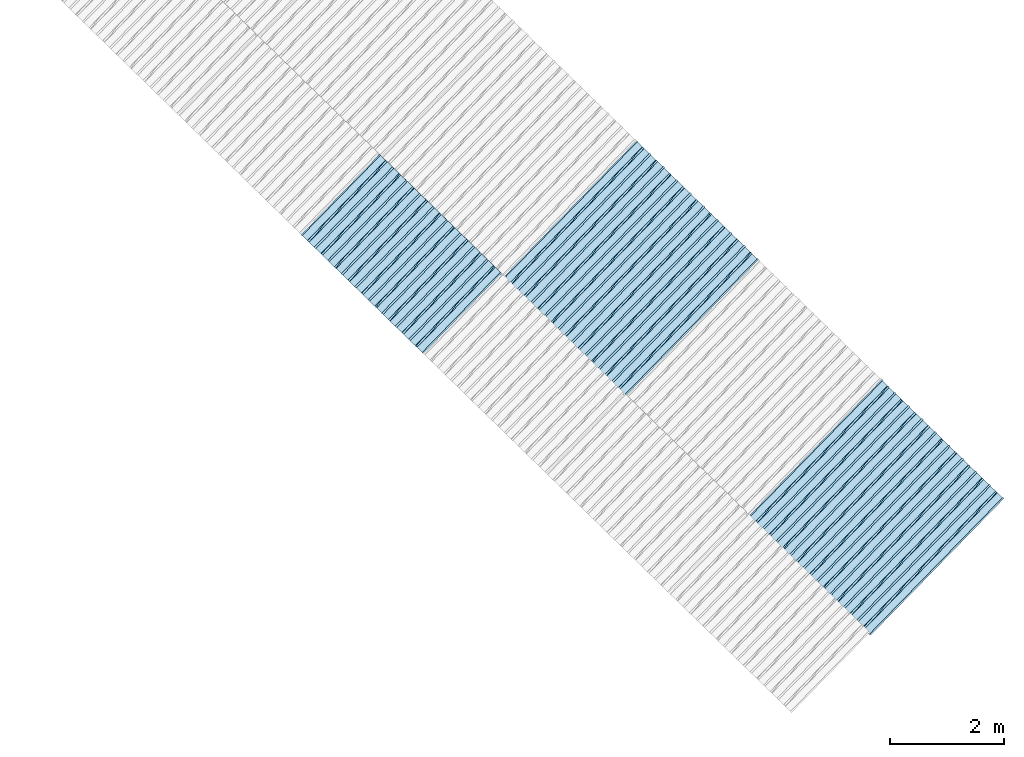
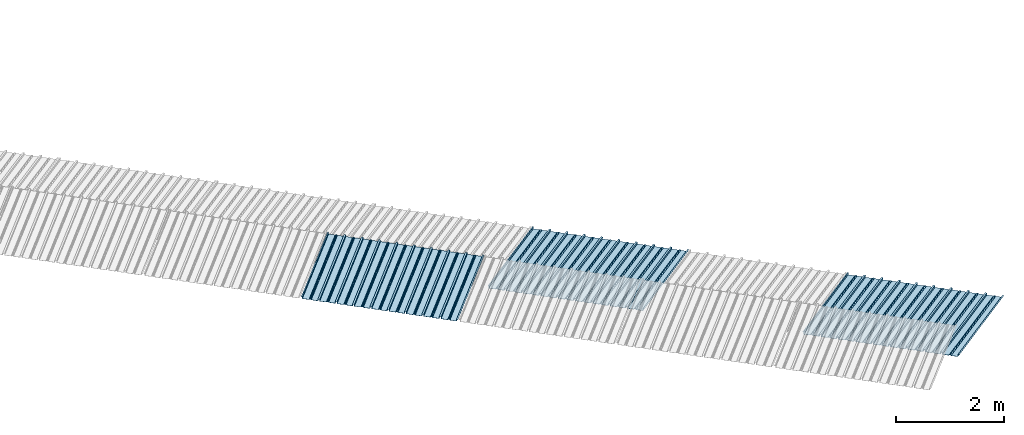
# One storey, part 4 of 8: 3 plates, 2 elements without a shape of their own.
"""IFC4 building model written with IfcOpenShell, lengths in metres."""

from ifc_helpers import new_model, entity, si_unit, converted_unit, direction, frame, origin, place, context, subcontext, project, spatial, line, arc, indexed_curve, outline, extrude, source, transform, mapped, material, type_object, type_shapes, element, aggregate, save


model = new_model("IFC4")

# Units and contexts
model_context = context("Model", 3, precision=1e-05, world=origin(), true_north=direction((6.123233995736766e-17, 1.0)))
body_context = subcontext(model_context, "Body", "Model", "MODEL_VIEW")
ifc_project = project(units=[si_unit("LENGTHUNIT", "METRE"), si_unit("AREAUNIT", "SQUARE_METRE"), si_unit("VOLUMEUNIT", "CUBIC_METRE"), converted_unit("PLANEANGLEUNIT", "DEGREE", entity("IfcPlaneAngleMeasure", 0.017453292519943278), si_unit("PLANEANGLEUNIT", "RADIAN"), dimensions=[0, 0, 0, 0, 0, 0, 0])], contexts=[model_context])

# Site, building, storey
site_placement = place(None, frame((0.0, 0.0, 0.0), z_axis=(0.0, 0.0, 1.0), x_axis=(0.7160934825303189, -0.6980043870045516, 0.0)))
site = spatial("IfcSite", under=ifc_project, at=site_placement, CompositionType="ELEMENT")
building_placement = place(site_placement, origin())
building = spatial("IfcBuilding", under=site, at=building_placement, CompositionType="ELEMENT")
storey_placement = place(building_placement, frame((0.0, 0.0, -1.24)))
storey = spatial("IfcBuildingStorey", under=building, at=storey_placement, Name="Livello 5", CompositionType="ELEMENT", Elevation=-1.24)

# Roof, plate
curtain_wall_type = type_object("IfcCurtainWallType", Name="Vetrata Copertura 2", PredefinedType="NOTDEFINED")
roof_1_placement = place(storey_placement, frame((0.0, 0.0, 1.24)))
roof_1 = element("IfcRoof", 1, at=roof_1_placement, inside=storey, type_object=curtain_wall_type, Name="Vetrata Copertura 2", ObjectType="Vetrata Copertura 2", PredefinedType="SHED_ROOF")
ifc_material = material(Name="Default")
plate_type_1 = type_object("IfcPlateType", Name="Pannello copertura:Pannello copertura", PredefinedType="CURTAIN_PANEL", material=ifc_material)
shared_shape_1 = source(origin(), body_context, "Body", "SweptSolid", [
    extrude(outline(indexed_curve([(1.339910560042256, -0.015785714285718594), (1.4699105600422562, -0.015785714285719003), (1.4699105600422562, 0.024214285714281004), (1.494919197675959, 0.02421428571428092), (1.494919197675959, 0.027214285714280917), (1.466910560042256, 0.027214285714281014), (1.466910560042256, -0.012785714285718995), (1.3417510978483753, -0.012785714285718492), (1.3199105600422556, 4.9134324369942785e-05), (1.2980700222361363, -0.012785714285718328), (1.1729105600422558, -0.01278571428571804), (1.1729105600422558, 0.02721428571428197), (1.136910560042256, 0.027214285714282097), (1.136910560042256, -0.012785714285717937), (1.0117510978483748, -0.01278571428571754), (0.9899105600422554, 4.913432437100935e-05), (0.968070022236136, -0.01278571428571726), (0.8429105600422558, -0.012785714285716971), (0.842910560042256, 0.027214285714283023), (0.8069105600422554, 0.027214285714283144), (0.8069105600422554, -0.01278571428571687), (0.6817510978483748, -0.012785714285716475), (0.6599105600422555, 4.9134324372075926e-05), (0.6380700222361361, -0.012785714285716196), (0.5129105600422553, -0.012785714285715915), (0.5129105600422554, 0.027214285714284105), (0.47691056004225557, 0.027214285714284227), (0.47691056004225557, -0.012785714285715804), (0.3517510978483749, -0.012785714285715427), (0.32991056004225544, 4.9134324373142496e-05), (0.3080700222361361, -0.012785714285715127), (0.18291056004225528, -0.012785714285714848), (0.18291056004225553, 0.027214285714285157), (0.1469105600422553, 0.02721428571428528), (0.14691056004225533, -0.012785714285714738), (0.021751097848374697, -0.01278571428571434), (-8.943995774469983e-05, 4.913432437420907e-05), (-0.021929977763864118, -0.01278571428571406), (-0.1470894399577447, -0.012785714285713783), (-0.14708943995774473, 0.02721428571428624), (-0.18308943995774493, 0.027214285714286364), (-0.1830894399577449, -0.012785714285713672), (-0.30824890215162537, -0.012785714285713215), (-0.33008943995774487, 4.9134324375275644e-05), (-0.3519299777638641, -0.012785714285712995), (-0.47708943995774494, -0.012785714285712714), (-0.4770894399577447, 0.02721428571428729), (-0.5130894399577449, 0.02721428571428741), (-0.5130894399577449, -0.012785714285712603), (-0.6382489021516256, -0.012785714285712207), (-0.6600894399577448, 4.9134324376342214e-05), (-0.6819299777638644, -0.012785714285711926), (-0.8070894399577453, -0.012785714285711647), (-0.807089439957745, 0.027214285714288373), (-0.843089439957745, 0.027214285714288494), (-0.8430894399577447, -0.012785714285711538), (-0.968248902151626, -0.012785714285711083), (-0.9900894399577453, 4.9134324377408785e-05), (-1.0119299777638646, -0.012785714285710861), (-1.1370894399577456, -0.012785714285710582), (-1.1370894399577451, 0.02721428571428942), (-1.1730894399577452, 0.027214285714289545), (-1.1730894399577454, -0.012785714285710473), (-1.2982489021516257, -0.012785714285710093), (-1.3200894399577452, 4.9134324378475355e-05), (-1.3419299777638647, -0.012785714285709794), (-1.4670894399577457, -0.012785714285709513), (-1.4670894399577454, 0.027214285714290503), (-1.490089439957745, 0.027214285714290586), (-1.490089439957745, 0.024214285714290556), (-1.4700894399577447, 0.02421428571429049), (-1.4700894399577449, -0.015785714285709514), (-1.3400894399577452, -0.015785714285709924), (-1.3200894399577452, -0.0029508656756215236), (-1.3000894399577452, -0.015785714285710063), (-1.170089439957745, -0.015785714285710472), (-1.1700894399577453, 0.024214285714289543), (-1.140089439957745, 0.02421428571428944), (-1.1400894399577455, -0.015785714285710583), (-1.0100894399577454, -0.015785714285710992), (-0.9900894399577453, -0.00295086567562259), (-0.9700894399577453, -0.015785714285711128), (-0.8400894399577448, -0.01578571428571154), (-0.8400894399577451, 0.024214285714288453), (-0.8100894399577452, 0.024214285714288356), (-0.8100894399577452, -0.015785714285711648), (-0.6800894399577451, -0.015785714285712012), (-0.6600894399577448, -0.0029508656756236573), (-0.6400894399577448, -0.015785714285712196), (-0.5100894399577451, -0.015785714285712606), (-0.5100894399577451, 0.024214285714287406), (-0.4800894399577449, 0.024214285714287305), (-0.4800894399577449, -0.015785714285712713), (-0.350089439957745, -0.01578571428571316), (-0.33008943995774487, -0.0029508656756247237), (-0.31008943995774485, -0.01578571428571326), (-0.1800894399577448, -0.015785714285713674), (-0.1800894399577448, 0.024214285714286323), (-0.1500894399577446, 0.02421428571428622), (-0.15008943995774485, -0.015785714285713782), (-0.020089439957744877, -0.015785714285714264), (-8.943995774473269e-05, -0.00295086567562579), (0.01991056004225521, -0.015785714285714323), (0.14991056004225545, -0.01578571428571474), (0.14991056004225542, 0.024214285714285272), (0.17991056004225567, 0.02421428571428517), (0.1799105600422554, -0.01578571428571485), (0.30991056004225526, -0.01578571428571532), (0.32991056004225544, -0.0029508656756268565), (0.3499105600422554, -0.015785714285715395), (0.47991056004225535, -0.015785714285715804), (0.47991056004225535, 0.02421428571428419), (0.5099105600422553, 0.02421428571428409), (0.5099105600422552, -0.015785714285715916), (0.6399105600422554, -0.015785714285716325), (0.6599105600422555, -0.002950865675627923), (0.6799105600422555, -0.01578571428571646), (0.8099105600422557, -0.015785714285716873), (0.8099105600422557, 0.02421428571428314), (0.8399105600422555, 0.02421428571428304), (0.8399105600422554, -0.015785714285716974), (0.9699105600422554, -0.015785714285717393), (0.9899105600422554, -0.0029508656756289894), (1.0099105600422555, -0.01578571428571753), (1.1399105600422557, -0.015785714285717938), (1.1399105600422557, 0.024214285714282077), (1.169910560042256, 0.024214285714281972), (1.1699105600422557, -0.01578571428571804), (1.2999105600422558, -0.01578571428571846), (1.3199105600422558, -0.0029508656756300567)], segments=[line(1, 2, 3, 4, 5, 6, 7, 8), arc(8, 9, 10), line(10, 11, 12, 13, 14, 15), arc(15, 16, 17), line(17, 18, 19, 20, 21, 22), arc(22, 23, 24), line(24, 25, 26, 27, 28, 29), arc(29, 30, 31), line(31, 32, 33, 34, 35, 36), arc(36, 37, 38), line(38, 39, 40, 41, 42, 43), arc(43, 44, 45), line(45, 46, 47, 48, 49, 50), arc(50, 51, 52), line(52, 53, 54, 55, 56, 57), arc(57, 58, 59), line(59, 60, 61, 62, 63, 64), arc(64, 65, 66), line(66, 67, 68, 69, 70, 71, 72, 73), arc(73, 74, 75), line(75, 76, 77, 78, 79, 80), arc(80, 81, 82), line(82, 83, 84, 85, 86, 87), arc(87, 88, 89), line(89, 90, 91, 92, 93, 94), arc(94, 95, 96), line(96, 97, 98, 99, 100, 101), arc(101, 102, 103), line(103, 104, 105, 106, 107, 108), arc(108, 109, 110), line(110, 111, 112, 113, 114, 115), arc(115, 116, 117), line(117, 118, 119, 120, 121, 122), arc(122, 123, 124), line(124, 125, 126, 127, 128, 129), arc(129, 130, 1)], self_intersect=False)), frame((8.080232403624576e-05, -0.015785714285719014, 0.0), z_axis=(0.0, 0.0, -1.0), x_axis=(1.0, 0.0, 0.0)), (0.0, 0.0, -1.0), 1.9691142879617602),
])
type_shapes(plate_type_1, [shared_shape_1])
plate_1_placement = place(roof_1_placement, frame((-2.232101380827111, -6.922854376535778, -1.0800000000000003), z_axis=(0.0, 0.9980594686585702, 0.0622679453729828), x_axis=(1.0, 0.0, 0.0)))
plate_1 = element("IfcPlate", 2, at=plate_1_placement, type_object=plate_type_1, material=ifc_material, Name="Pannello copertura:Pannello copertura", ObjectType="Pannello copertura:Pannello copertura", PredefinedType="CURTAIN_PANEL", context=body_context, shape_type="MappedRepresentation", body=[
    mapped(shared_shape_1, transform((0.0, 0.0, 0.0), scale=1.0)),
])
aggregate(roof_1, [plate_1])

# Roof, plates
roof_2_placement = place(storey_placement, frame((0.0, 0.0, 1.24)))
roof_2 = element("IfcRoof", 3, at=roof_2_placement, inside=storey, type_object=curtain_wall_type, Name="Vetrata Copertura 2", ObjectType="Vetrata Copertura 2", PredefinedType="SHED_ROOF")
plate_type_2 = type_object("IfcPlateType", Name="Pannello copertura:Pannello copertura", PredefinedType="CURTAIN_PANEL", material=ifc_material)
shared_shape_2 = source(origin(), body_context, "Body", "SweptSolid", [
    extrude(outline(indexed_curve([(1.339910560042256, -0.015785714285718594), (1.4699105600422562, -0.015785714285719003), (1.4699105600422562, 0.024214285714281004), (1.494919197675959, 0.02421428571428092), (1.494919197675959, 0.027214285714280917), (1.466910560042256, 0.027214285714281014), (1.466910560042256, -0.012785714285718995), (1.3417510978483753, -0.012785714285718492), (1.3199105600422556, 4.9134324369942785e-05), (1.2980700222361363, -0.012785714285718328), (1.1729105600422558, -0.01278571428571804), (1.1729105600422558, 0.02721428571428197), (1.136910560042256, 0.027214285714282097), (1.136910560042256, -0.012785714285717937), (1.0117510978483748, -0.01278571428571754), (0.9899105600422554, 4.913432437100935e-05), (0.968070022236136, -0.01278571428571726), (0.8429105600422558, -0.012785714285716971), (0.842910560042256, 0.027214285714283023), (0.8069105600422554, 0.027214285714283144), (0.8069105600422554, -0.01278571428571687), (0.6817510978483748, -0.012785714285716475), (0.6599105600422555, 4.9134324372075926e-05), (0.6380700222361361, -0.012785714285716196), (0.5129105600422553, -0.012785714285715915), (0.5129105600422554, 0.027214285714284105), (0.47691056004225557, 0.027214285714284227), (0.47691056004225557, -0.012785714285715804), (0.3517510978483749, -0.012785714285715427), (0.32991056004225544, 4.9134324373142496e-05), (0.3080700222361361, -0.012785714285715127), (0.18291056004225528, -0.012785714285714848), (0.18291056004225553, 0.027214285714285157), (0.1469105600422553, 0.02721428571428528), (0.14691056004225533, -0.012785714285714738), (0.021751097848374697, -0.01278571428571434), (-8.943995774469983e-05, 4.913432437420907e-05), (-0.021929977763864118, -0.01278571428571406), (-0.1470894399577447, -0.012785714285713783), (-0.14708943995774473, 0.02721428571428624), (-0.18308943995774493, 0.027214285714286364), (-0.1830894399577449, -0.012785714285713672), (-0.30824890215162537, -0.012785714285713215), (-0.33008943995774487, 4.9134324375275644e-05), (-0.3519299777638641, -0.012785714285712995), (-0.47708943995774494, -0.012785714285712714), (-0.4770894399577447, 0.02721428571428729), (-0.5130894399577449, 0.02721428571428741), (-0.5130894399577449, -0.012785714285712603), (-0.6382489021516256, -0.012785714285712207), (-0.6600894399577448, 4.9134324376342214e-05), (-0.6819299777638644, -0.012785714285711926), (-0.8070894399577453, -0.012785714285711647), (-0.807089439957745, 0.027214285714288373), (-0.843089439957745, 0.027214285714288494), (-0.8430894399577447, -0.012785714285711538), (-0.968248902151626, -0.012785714285711083), (-0.9900894399577453, 4.9134324377408785e-05), (-1.0119299777638646, -0.012785714285710861), (-1.1370894399577456, -0.012785714285710582), (-1.1370894399577451, 0.02721428571428942), (-1.1730894399577452, 0.027214285714289545), (-1.1730894399577454, -0.012785714285710473), (-1.2982489021516257, -0.012785714285710093), (-1.3200894399577452, 4.9134324378475355e-05), (-1.3419299777638647, -0.012785714285709794), (-1.4670894399577457, -0.012785714285709513), (-1.4670894399577454, 0.027214285714290503), (-1.490089439957745, 0.027214285714290586), (-1.490089439957745, 0.024214285714290556), (-1.4700894399577447, 0.02421428571429049), (-1.4700894399577449, -0.015785714285709514), (-1.3400894399577452, -0.015785714285709924), (-1.3200894399577452, -0.0029508656756215236), (-1.3000894399577452, -0.015785714285710063), (-1.170089439957745, -0.015785714285710472), (-1.1700894399577453, 0.024214285714289543), (-1.140089439957745, 0.02421428571428944), (-1.1400894399577455, -0.015785714285710583), (-1.0100894399577454, -0.015785714285710992), (-0.9900894399577453, -0.00295086567562259), (-0.9700894399577453, -0.015785714285711128), (-0.8400894399577448, -0.01578571428571154), (-0.8400894399577451, 0.024214285714288453), (-0.8100894399577452, 0.024214285714288356), (-0.8100894399577452, -0.015785714285711648), (-0.6800894399577451, -0.015785714285712012), (-0.6600894399577448, -0.0029508656756236573), (-0.6400894399577448, -0.015785714285712196), (-0.5100894399577451, -0.015785714285712606), (-0.5100894399577451, 0.024214285714287406), (-0.4800894399577449, 0.024214285714287305), (-0.4800894399577449, -0.015785714285712713), (-0.350089439957745, -0.01578571428571316), (-0.33008943995774487, -0.0029508656756247237), (-0.31008943995774485, -0.01578571428571326), (-0.1800894399577448, -0.015785714285713674), (-0.1800894399577448, 0.024214285714286323), (-0.1500894399577446, 0.02421428571428622), (-0.15008943995774485, -0.015785714285713782), (-0.020089439957744877, -0.015785714285714264), (-8.943995774473269e-05, -0.00295086567562579), (0.01991056004225521, -0.015785714285714323), (0.14991056004225545, -0.01578571428571474), (0.14991056004225542, 0.024214285714285272), (0.17991056004225567, 0.02421428571428517), (0.1799105600422554, -0.01578571428571485), (0.30991056004225526, -0.01578571428571532), (0.32991056004225544, -0.0029508656756268565), (0.3499105600422554, -0.015785714285715395), (0.47991056004225535, -0.015785714285715804), (0.47991056004225535, 0.02421428571428419), (0.5099105600422553, 0.02421428571428409), (0.5099105600422552, -0.015785714285715916), (0.6399105600422554, -0.015785714285716325), (0.6599105600422555, -0.002950865675627923), (0.6799105600422555, -0.01578571428571646), (0.8099105600422557, -0.015785714285716873), (0.8099105600422557, 0.02421428571428314), (0.8399105600422555, 0.02421428571428304), (0.8399105600422554, -0.015785714285716974), (0.9699105600422554, -0.015785714285717393), (0.9899105600422554, -0.0029508656756289894), (1.0099105600422555, -0.01578571428571753), (1.1399105600422557, -0.015785714285717938), (1.1399105600422557, 0.024214285714282077), (1.169910560042256, 0.024214285714281972), (1.1699105600422557, -0.01578571428571804), (1.2999105600422558, -0.01578571428571846), (1.3199105600422558, -0.0029508656756300567)], segments=[line(1, 2, 3, 4, 5, 6, 7, 8), arc(8, 9, 10), line(10, 11, 12, 13, 14, 15), arc(15, 16, 17), line(17, 18, 19, 20, 21, 22), arc(22, 23, 24), line(24, 25, 26, 27, 28, 29), arc(29, 30, 31), line(31, 32, 33, 34, 35, 36), arc(36, 37, 38), line(38, 39, 40, 41, 42, 43), arc(43, 44, 45), line(45, 46, 47, 48, 49, 50), arc(50, 51, 52), line(52, 53, 54, 55, 56, 57), arc(57, 58, 59), line(59, 60, 61, 62, 63, 64), arc(64, 65, 66), line(66, 67, 68, 69, 70, 71, 72, 73), arc(73, 74, 75), line(75, 76, 77, 78, 79, 80), arc(80, 81, 82), line(82, 83, 84, 85, 86, 87), arc(87, 88, 89), line(89, 90, 91, 92, 93, 94), arc(94, 95, 96), line(96, 97, 98, 99, 100, 101), arc(101, 102, 103), line(103, 104, 105, 106, 107, 108), arc(108, 109, 110), line(110, 111, 112, 113, 114, 115), arc(115, 116, 117), line(117, 118, 119, 120, 121, 122), arc(122, 123, 124), line(124, 125, 126, 127, 128, 129), arc(129, 130, 1)], self_intersect=False)), frame((8.080232403624576e-05, -0.015785714285719014, 0.0), z_axis=(0.0, 0.0, -1.0), x_axis=(1.0, 0.0, 0.0)), (0.0, 0.0, -1.0), 3.472878469300717),
])
type_shapes(plate_type_2, [shared_shape_2])
plate_2_placement = place(roof_2_placement, frame((0.825161900462189, -4.997561216564662, -1.6240000000000003), z_axis=(0.0, 0.9632563788424056, -0.26858359707810914), x_axis=(1.0, 0.0, 0.0)))
plate_2 = element("IfcPlate", 4, at=plate_2_placement, type_object=plate_type_2, material=ifc_material, Name="Pannello copertura:Pannello copertura", ObjectType="Pannello copertura:Pannello copertura", PredefinedType="CURTAIN_PANEL", context=body_context, shape_type="MappedRepresentation", body=[
    mapped(shared_shape_2, transform((0.0, 0.0, 0.0), scale=1.0)),
])
plate_type_3 = type_object("IfcPlateType", Name="Pannello copertura:Pannello copertura", PredefinedType="CURTAIN_PANEL", material=ifc_material)
shared_shape_3 = source(origin(), body_context, "Body", "SweptSolid", [
    extrude(outline(indexed_curve([(1.339910560042256, -0.015785714285718594), (1.4699105600422562, -0.015785714285719003), (1.4699105600422562, 0.024214285714281004), (1.494919197675959, 0.02421428571428092), (1.494919197675959, 0.027214285714280917), (1.466910560042256, 0.027214285714281014), (1.466910560042256, -0.012785714285718995), (1.3417510978483753, -0.012785714285718492), (1.3199105600422556, 4.9134324369942785e-05), (1.2980700222361363, -0.012785714285718328), (1.1729105600422558, -0.01278571428571804), (1.1729105600422558, 0.02721428571428197), (1.136910560042256, 0.027214285714282097), (1.136910560042256, -0.012785714285717937), (1.0117510978483748, -0.01278571428571754), (0.9899105600422554, 4.913432437100935e-05), (0.968070022236136, -0.01278571428571726), (0.8429105600422558, -0.012785714285716971), (0.842910560042256, 0.027214285714283023), (0.8069105600422554, 0.027214285714283144), (0.8069105600422554, -0.01278571428571687), (0.6817510978483748, -0.012785714285716475), (0.6599105600422555, 4.9134324372075926e-05), (0.6380700222361361, -0.012785714285716196), (0.5129105600422553, -0.012785714285715915), (0.5129105600422554, 0.027214285714284105), (0.47691056004225557, 0.027214285714284227), (0.47691056004225557, -0.012785714285715804), (0.3517510978483749, -0.012785714285715427), (0.32991056004225544, 4.9134324373142496e-05), (0.3080700222361361, -0.012785714285715127), (0.18291056004225528, -0.012785714285714848), (0.18291056004225553, 0.027214285714285157), (0.1469105600422553, 0.02721428571428528), (0.14691056004225533, -0.012785714285714738), (0.021751097848374697, -0.01278571428571434), (-8.943995774469983e-05, 4.913432437420907e-05), (-0.021929977763864118, -0.01278571428571406), (-0.1470894399577447, -0.012785714285713783), (-0.14708943995774473, 0.02721428571428624), (-0.18308943995774493, 0.027214285714286364), (-0.1830894399577449, -0.012785714285713672), (-0.30824890215162537, -0.012785714285713215), (-0.33008943995774487, 4.9134324375275644e-05), (-0.3519299777638641, -0.012785714285712995), (-0.47708943995774494, -0.012785714285712714), (-0.4770894399577447, 0.02721428571428729), (-0.5130894399577449, 0.02721428571428741), (-0.5130894399577449, -0.012785714285712603), (-0.6382489021516256, -0.012785714285712207), (-0.6600894399577448, 4.9134324376342214e-05), (-0.6819299777638644, -0.012785714285711926), (-0.8070894399577453, -0.012785714285711647), (-0.807089439957745, 0.027214285714288373), (-0.843089439957745, 0.027214285714288494), (-0.8430894399577447, -0.012785714285711538), (-0.968248902151626, -0.012785714285711083), (-0.9900894399577453, 4.9134324377408785e-05), (-1.0119299777638646, -0.012785714285710861), (-1.1370894399577456, -0.012785714285710582), (-1.1370894399577451, 0.02721428571428942), (-1.1730894399577452, 0.027214285714289545), (-1.1730894399577454, -0.012785714285710473), (-1.2982489021516257, -0.012785714285710093), (-1.3200894399577452, 4.9134324378475355e-05), (-1.3419299777638647, -0.012785714285709794), (-1.4670894399577457, -0.012785714285709513), (-1.4670894399577454, 0.027214285714290503), (-1.490089439957745, 0.027214285714290586), (-1.490089439957745, 0.024214285714290556), (-1.4700894399577447, 0.02421428571429049), (-1.4700894399577449, -0.015785714285709514), (-1.3400894399577452, -0.015785714285709924), (-1.3200894399577452, -0.0029508656756215236), (-1.3000894399577452, -0.015785714285710063), (-1.170089439957745, -0.015785714285710472), (-1.1700894399577453, 0.024214285714289543), (-1.140089439957745, 0.02421428571428944), (-1.1400894399577455, -0.015785714285710583), (-1.0100894399577454, -0.015785714285710992), (-0.9900894399577453, -0.00295086567562259), (-0.9700894399577453, -0.015785714285711128), (-0.8400894399577448, -0.01578571428571154), (-0.8400894399577451, 0.024214285714288453), (-0.8100894399577452, 0.024214285714288356), (-0.8100894399577452, -0.015785714285711648), (-0.6800894399577451, -0.015785714285712012), (-0.6600894399577448, -0.0029508656756236573), (-0.6400894399577448, -0.015785714285712196), (-0.5100894399577451, -0.015785714285712606), (-0.5100894399577451, 0.024214285714287406), (-0.4800894399577449, 0.024214285714287305), (-0.4800894399577449, -0.015785714285712713), (-0.350089439957745, -0.01578571428571316), (-0.33008943995774487, -0.0029508656756247237), (-0.31008943995774485, -0.01578571428571326), (-0.1800894399577448, -0.015785714285713674), (-0.1800894399577448, 0.024214285714286323), (-0.1500894399577446, 0.02421428571428622), (-0.15008943995774485, -0.015785714285713782), (-0.020089439957744877, -0.015785714285714264), (-8.943995774473269e-05, -0.00295086567562579), (0.01991056004225521, -0.015785714285714323), (0.14991056004225545, -0.01578571428571474), (0.14991056004225542, 0.024214285714285272), (0.17991056004225567, 0.02421428571428517), (0.1799105600422554, -0.01578571428571485), (0.30991056004225526, -0.01578571428571532), (0.32991056004225544, -0.0029508656756268565), (0.3499105600422554, -0.015785714285715395), (0.47991056004225535, -0.015785714285715804), (0.47991056004225535, 0.02421428571428419), (0.5099105600422553, 0.02421428571428409), (0.5099105600422552, -0.015785714285715916), (0.6399105600422554, -0.015785714285716325), (0.6599105600422555, -0.002950865675627923), (0.6799105600422555, -0.01578571428571646), (0.8099105600422557, -0.015785714285716873), (0.8099105600422557, 0.02421428571428314), (0.8399105600422555, 0.02421428571428304), (0.8399105600422554, -0.015785714285716974), (0.9699105600422554, -0.015785714285717393), (0.9899105600422554, -0.0029508656756289894), (1.0099105600422555, -0.01578571428571753), (1.1399105600422557, -0.015785714285717938), (1.1399105600422557, 0.024214285714282077), (1.169910560042256, 0.024214285714281972), (1.1699105600422557, -0.01578571428571804), (1.2999105600422558, -0.01578571428571846), (1.3199105600422558, -0.0029508656756300567)], segments=[line(1, 2, 3, 4, 5, 6, 7, 8), arc(8, 9, 10), line(10, 11, 12, 13, 14, 15), arc(15, 16, 17), line(17, 18, 19, 20, 21, 22), arc(22, 23, 24), line(24, 25, 26, 27, 28, 29), arc(29, 30, 31), line(31, 32, 33, 34, 35, 36), arc(36, 37, 38), line(38, 39, 40, 41, 42, 43), arc(43, 44, 45), line(45, 46, 47, 48, 49, 50), arc(50, 51, 52), line(52, 53, 54, 55, 56, 57), arc(57, 58, 59), line(59, 60, 61, 62, 63, 64), arc(64, 65, 66), line(66, 67, 68, 69, 70, 71, 72, 73), arc(73, 74, 75), line(75, 76, 77, 78, 79, 80), arc(80, 81, 82), line(82, 83, 84, 85, 86, 87), arc(87, 88, 89), line(89, 90, 91, 92, 93, 94), arc(94, 95, 96), line(96, 97, 98, 99, 100, 101), arc(101, 102, 103), line(103, 104, 105, 106, 107, 108), arc(108, 109, 110), line(110, 111, 112, 113, 114, 115), arc(115, 116, 117), line(117, 118, 119, 120, 121, 122), arc(122, 123, 124), line(124, 125, 126, 127, 128, 129), arc(129, 130, 1)], self_intersect=False)), frame((8.080232403624576e-05, -0.015785714285719014, 0.0), z_axis=(0.0, 0.0, -1.0), x_axis=(1.0, 0.0, 0.0)), (0.0, 0.0, -1.0), 3.472878469300717),
])
type_shapes(plate_type_3, [shared_shape_3])
plate_3_placement = place(roof_2_placement, frame((6.820734864186466, -4.997561216564662, -1.6240000000000003), z_axis=(0.0, 0.9632563788424056, -0.26858359707810914), x_axis=(1.0, 0.0, 0.0)))
plate_3 = element("IfcPlate", 5, at=plate_3_placement, type_object=plate_type_3, material=ifc_material, Name="Pannello copertura:Pannello copertura", ObjectType="Pannello copertura:Pannello copertura", PredefinedType="CURTAIN_PANEL", context=body_context, shape_type="MappedRepresentation", body=[
    mapped(shared_shape_3, transform((0.0, 0.0, 0.0), scale=1.0)),
])
aggregate(roof_2, [plate_2, plate_3])

save(model, "model.ifc")
